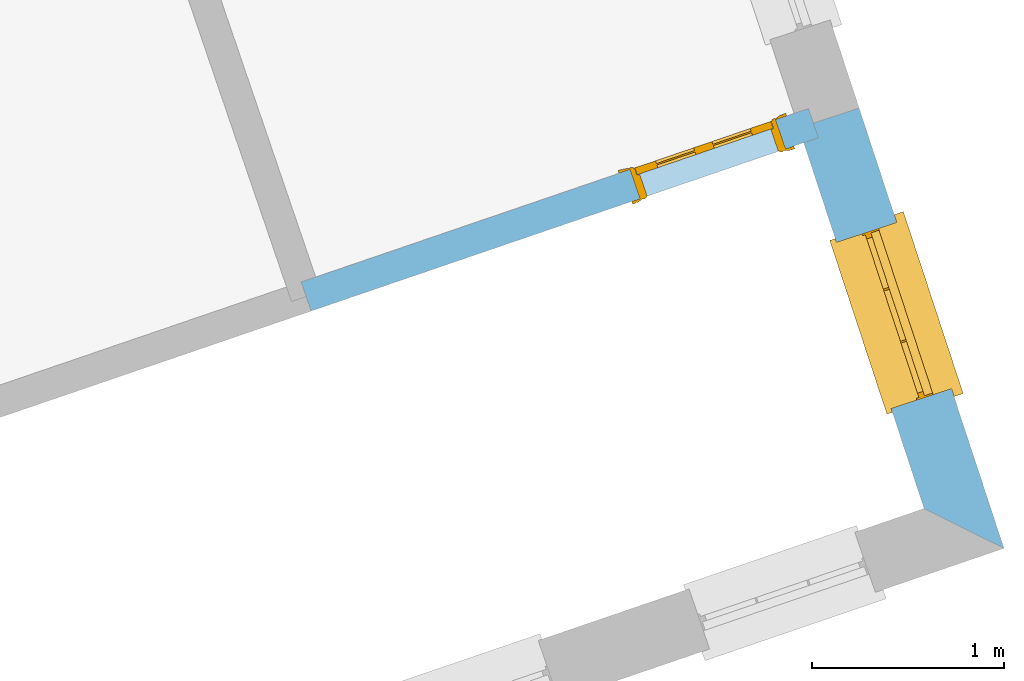
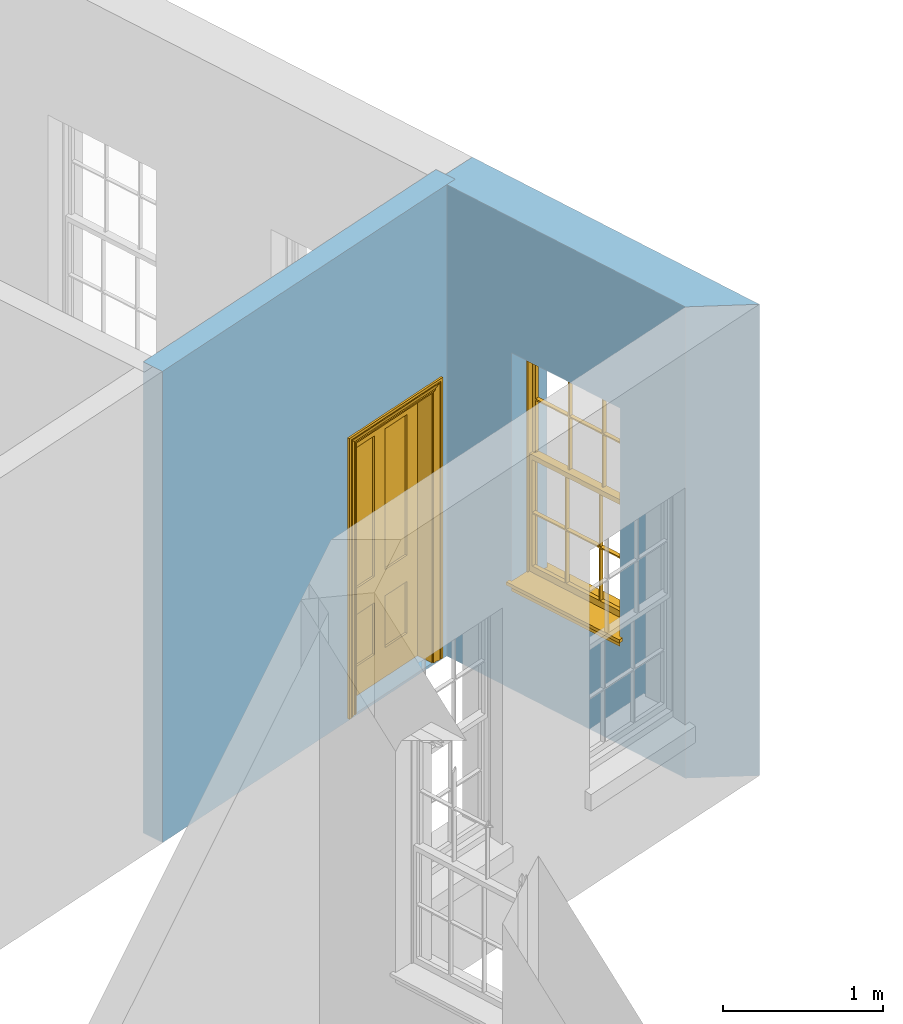
# One storey, part 7 of 10: 1 door, 1 window, 2 openings, plus 2 elements that do not belong to this part.
"""IFC2X3 building model written with IfcOpenShell, lengths in metres."""

import ifcopenshell
import ifcopenshell.guid

model = None  # the IFC model being written
_history = None  # IfcOwnerHistory: only IFC2X3 demands one
_inside = {}  # id of a spatial element -> (the spatial element, [elements in it])
_under = {}  # id of a project, library or spatial element -> (it, [spatial elements below it])
_declared = {}  # id of a project -> (the project, [libraries it declares])
_typed = {}  # id of a type object -> (the type object, [elements of that type])
_made_of = {}  # id of a material, layer set ... -> (it, [elements and type objects made of it])


def new_model(schema):
    """Start an empty IFC model of exactly this schema.

    Asked for "IFC4X3", IfcOpenShell would pick the latest addendum, in which some entities
    have other attributes; the version numbers below select the first issue.
    IFC2X3 requires an IfcOwnerHistory on every rooted entity: one is made here for all.
    """
    global model, _history
    if schema == "IFC4X3":
        model = ifcopenshell.file(schema_version=(4, 3, 0, 0))
    else:
        model = ifcopenshell.file(schema=schema)
    _inside.clear()
    _under.clear()
    _declared.clear()
    _typed.clear()
    _made_of.clear()
    _history = None
    if model.schema == "IFC2X3":
        org = make("IfcOrganization", Name="unknown")
        user = make(
            "IfcPersonAndOrganization",
            ThePerson=make("IfcPerson", FamilyName="unknown"),
            TheOrganization=org,
        )
        app = make(
            "IfcApplication",
            ApplicationDeveloper=org,
            Version="unknown",
            ApplicationFullName="unknown",
            ApplicationIdentifier="unknown",
        )
        _history = make(
            "IfcOwnerHistory",
            OwningUser=user,
            OwningApplication=app,
            ChangeAction="ADDED",
            CreationDate=0,
        )
    return model


def make(cls, **values):
    """One entity of the class cls with the attributes given. An attribute that is None is left unset."""
    return model.create_entity(
        cls, **{name: value for name, value in values.items() if value is not None}
    )


def rooted(cls, **values):
    """An entity with a GlobalId (a new one), such as an element, a storey or a relation."""
    return make(cls, GlobalId=ifcopenshell.guid.new(), OwnerHistory=_history, **values)


def si_unit(unit_type, name, prefix=None):
    """IfcSIUnit, for example si_unit("LENGTHUNIT", "METRE", prefix="MILLI")."""
    return make("IfcSIUnit", UnitType=unit_type, Prefix=prefix, Name=name)


def assignment(units):
    """IfcUnitAssignment: the units of a project."""
    return None if units is None else make("IfcUnitAssignment", Units=units)


def point(xyz):
    """IfcCartesianPoint."""
    return None if xyz is None else make("IfcCartesianPoint", Coordinates=xyz)


def direction(xyz):
    """IfcDirection."""
    return None if xyz is None else make("IfcDirection", DirectionRatios=xyz)


def frame(location, z_axis=None, x_axis=None):
    """IfcAxis2Placement3D, a coordinate frame: its origin and axes. An axis left out is left unset."""
    return make(
        "IfcAxis2Placement3D",
        Location=point(location),
        Axis=direction(z_axis),
        RefDirection=direction(x_axis),
    )


def origin():
    """The frame at (0, 0, 0) with its axes left unset."""
    return frame((0.0, 0.0, 0.0))


def place(relative_to, where):
    """IfcLocalPlacement: puts the frame where relative to a parent placement (None: the world)."""
    return make(
        "IfcLocalPlacement", PlacementRelTo=relative_to, RelativePlacement=where
    )


def context(
    kind, dimensions, precision=None, world=None, true_north=None, identifier=None
):
    """IfcGeometricRepresentationContext, for example the 3D "Model" context."""
    return make(
        "IfcGeometricRepresentationContext",
        ContextIdentifier=identifier,
        ContextType=kind,
        CoordinateSpaceDimension=dimensions,
        Precision=precision,
        WorldCoordinateSystem=world,
        TrueNorth=true_north,
    )


def subcontext(parent, identifier, kind, view, scale=None):
    """IfcGeometricRepresentationSubContext, for example "Body" below "Model"."""
    return make(
        "IfcGeometricRepresentationSubContext",
        ContextIdentifier=identifier,
        ContextType=kind,
        ParentContext=parent,
        TargetScale=scale,
        TargetView=view,
    )


def project(units=None, contexts=None):
    """IfcProject with its units and contexts."""
    return rooted(
        "IfcProject",
        Name="project",
        RepresentationContexts=contexts,
        UnitsInContext=assignment(units),
    )


def spatial(cls, under=None, at=None, **own):
    """A site, building, storey or space (cls), placed at a placement, below another one or the project."""
    s = rooted(cls, ObjectPlacement=at, **own)
    if under is not None:
        _under.setdefault(under.id(), (under, []))[1].append(s)
    return s


def polyline(points):
    """IfcPolyline through the points."""
    return make("IfcPolyline", Points=[point(p) for p in points])


def outline(outer, holes=None, kind="AREA"):
    """IfcArbitraryClosedProfileDef: a profile drawn as a closed curve; with holes, ...WithVoids."""
    if holes is None:
        return make("IfcArbitraryClosedProfileDef", ProfileType=kind, OuterCurve=outer)
    return make(
        "IfcArbitraryProfileDefWithVoids",
        ProfileType=kind,
        OuterCurve=outer,
        InnerCurves=holes,
    )


def extrude(swept, where, along, depth):
    """IfcExtrudedAreaSolid: the profile swept, set in the frame where, extruded along a direction by depth."""
    return make(
        "IfcExtrudedAreaSolid",
        SweptArea=swept,
        Position=where,
        ExtrudedDirection=direction(along),
        Depth=depth,
    )


def faces_of(points, faces, orient=None, outer=None):
    """IfcFace entities. A face is a list of loops; a loop is a list of indices into points, from 0.

    orient and outer hold one flag for each loop. By default every Orientation is true, the
    first loop of a face is its IfcFaceOuterBound and the others are IfcFaceBound.
    """
    made = []
    for i, loops in enumerate(faces):
        bounds = []
        for j, loop in enumerate(loops):
            is_outer = j == 0 if outer is None else outer[i][j]
            bounds.append(
                make(
                    "IfcFaceOuterBound" if is_outer else "IfcFaceBound",
                    Bound=make("IfcPolyLoop", Polygon=[points[k] for k in loop]),
                    Orientation=True if orient is None else orient[i][j],
                )
            )
        made.append(make("IfcFace", Bounds=bounds))
    return made


def faceted_brep(points, faces, orient=None, outer=None, voids=None):
    """IfcFacetedBrep: a solid bounded by flat faces; with voids (closed shells), ...WithVoids."""
    shared = [point(p) for p in points]
    hull = make("IfcClosedShell", CfsFaces=faces_of(shared, faces, orient, outer))
    if voids is None:
        return make("IfcFacetedBrep", Outer=hull)
    return make(
        "IfcFacetedBrepWithVoids",
        Outer=hull,
        Voids=[
            make(cls, CfsFaces=faces_of(shared, fs, o, b)) for cls, fs, o, b in voids
        ],
    )


def shape(context_of_items, identifier, shape_type, items):
    """IfcShapeRepresentation: the items that make up one representation, for example the "Body"."""
    return make(
        "IfcShapeRepresentation",
        ContextOfItems=context_of_items,
        RepresentationIdentifier=identifier,
        RepresentationType=shape_type,
        Items=items,
    )


def material(Name=None, Category=None):
    """IfcMaterial."""
    return make("IfcMaterial", Name=Name, Category=Category)


def layer(
    of_material, thickness, ventilated=None, Name=None, Category=None, Priority=None
):
    """IfcMaterialLayer: one layer of a wall or slab, of a material (None: an air gap)."""
    return make(
        "IfcMaterialLayer",
        Material=of_material,
        LayerThickness=thickness,
        IsVentilated=ventilated,
        Name=Name,
        Category=Category,
        Priority=Priority,
    )


def layer_set(layers, Name=None):
    """IfcMaterialLayerSet."""
    return make("IfcMaterialLayerSet", MaterialLayers=layers, LayerSetName=Name)


def layer_usage(for_layer_set, set_direction, sense, offset, extent=None):
    """IfcMaterialLayerSetUsage: how a layer set lies in its element."""
    return make(
        "IfcMaterialLayerSetUsage",
        ForLayerSet=for_layer_set,
        LayerSetDirection=set_direction,
        DirectionSense=sense,
        OffsetFromReferenceLine=offset,
        ReferenceExtent=extent,
    )


def made_of(thing, what):
    """Note that an element or type object is made of a material, layer set ...; save() writes the relation."""
    if what is not None:
        _made_of.setdefault(what.id(), (what, []))[1].append(thing)
    return thing


def element(
    cls,
    number,
    at=None,
    inside=None,
    cuts=None,
    type_object=None,
    material=None,
    context=None,
    identifier="Body",
    shape_type=None,
    held_by="IfcProductDefinitionShape",
    body=None,
    shapes=None,
    **own,
):
    """One element of the class cls, such as IfcWall. Its Tag is "e" and its number.

    at: its placement. inside: the storey or other place that contains it. cuts: it is an
    opening in that element (IfcRelVoidsElement). A single representation is given by context,
    identifier, shape_type and body (its items); several are given by shapes. held_by: the class
    of the entity that holds the representations. save() writes the other relations.
    """
    e = rooted(cls, Tag="e%d" % number, ObjectPlacement=at, **own)
    if body is not None:
        shapes = [shape(context, identifier, shape_type, body)]
    if shapes is not None:
        e.Representation = make(held_by, Representations=shapes)
    if inside is not None:
        _inside.setdefault(inside.id(), (inside, []))[1].append(e)
    if cuts is not None:
        rooted(
            "IfcRelVoidsElement", RelatingBuildingElement=cuts, RelatedOpeningElement=e
        )
    if type_object is not None:
        _typed.setdefault(type_object.id(), (type_object, []))[1].append(e)
    return made_of(e, material)


def fill(opening, filler):
    """IfcRelFillsElement: the door or window that sits in an opening."""
    return rooted(
        "IfcRelFillsElement",
        RelatingOpeningElement=opening,
        RelatedBuildingElement=filler,
    )


def aggregate(whole, parts):
    """IfcRelAggregates: a whole, such as a stair, and the parts it consists of."""
    return rooted("IfcRelAggregates", RelatingObject=whole, RelatedObjects=parts)


def save(model, path):
    """Write the relations noted so far, then the file.

    IfcRelAggregates (storeys below a building ...), IfcRelContainedInSpatialStructure (elements
    in a storey), IfcRelDefinesByType, IfcRelAssociatesMaterial and IfcRelDeclares: one each for
    every whole, place, type object, material and project.
    """
    for whole, parts in _under.values():
        aggregate(whole, parts)
    for where, things in _inside.values():
        rooted(
            "IfcRelContainedInSpatialStructure",
            RelatedElements=things,
            RelatingStructure=where,
        )
    for kind, things in _typed.values():
        rooted("IfcRelDefinesByType", RelatedObjects=things, RelatingType=kind)
    for what, things in _made_of.values():
        rooted("IfcRelAssociatesMaterial", RelatedObjects=things, RelatingMaterial=what)
    for by, libraries in _declared.values():
        rooted("IfcRelDeclares", RelatingContext=by, RelatedDefinitions=libraries)
    model.write(path)


model = new_model("IFC2X3")

# Units and contexts
model_context = context("Model", 3, world=origin())
body_context = subcontext(model_context, "Body", "Model", "MODEL_VIEW")
ifc_project = project(units=[si_unit("PLANEANGLEUNIT", "RADIAN"), si_unit("MASSUNIT", "GRAM", prefix="KILO"), si_unit("FORCEUNIT", "NEWTON", prefix="KILO"), si_unit("LENGTHUNIT", "METRE")], contexts=[model_context])

# Site, building, storey
site_placement = place(None, origin())
site = spatial("IfcSite", under=ifc_project, at=site_placement, CompositionType="ELEMENT")
building_placement = place(None, origin())
building = spatial("IfcBuilding", under=site, at=building_placement, Name="Building plot-2", CompositionType="ELEMENT")
storey_placement = place(None, frame((0.0, 0.0, 4.6)))
storey = spatial("IfcBuildingStorey", under=building, at=storey_placement, Name="Floor 1", CompositionType="ELEMENT", Elevation=4.6)

# Wall, opening, window
ifc_material_1 = material(Name="Masonry")
ifc_layer_1 = layer(ifc_material_1, 0.33, ventilated=False)
ifc_layer_set_1 = layer_set([ifc_layer_1], Name="My Wall")
ifc_layer_usage_1 = layer_usage(ifc_layer_set_1, "AXIS2", "NEGATIVE", 0.08)
wall_1_placement = place(storey_placement, origin())
wall_1 = element("IfcWallStandardCase", 1, at=wall_1_placement, inside=storey, material=ifc_layer_usage_1, Name="exterior", context=body_context, shape_type="SweptSolid", body=[
    extrude(outline(polyline([(36.6893138301649, 33.9125007833851), (37.1047195485034, 33.7057805140381), (36.3522408394225, 35.9930897647079), (36.0387683534412, 35.8899636257678), (36.6893138301649, 33.9125007833851)])), origin(), (0.0, 0.0, 1.0), 3.6),
])
opening_1_placement = place(storey_placement, frame((0.0, 0.0, 0.75)))
opening_1 = element("IfcOpeningElement", 2, at=opening_1_placement, cuts=wall_1, Name="Opening", ObjectType="Opening", context=body_context, shape_type="SweptSolid", body=[
    extrude(outline(polyline([(36.8320581914572, 34.5345891391136), (36.5476800507436, 35.3990132671227), (36.2342075647623, 35.2958871281825), (36.5185857054759, 34.4314630001735), (36.8320581914572, 34.5345891391136)])), origin(), (0.0, 0.0, 1.0), 1.82),
])
window_placement = place(storey_placement, frame((36.5945790354108, 34.4564632762802, 0.75), z_axis=(0.0, 0.0, 1.0), x_axis=(-0.284378140713635, 0.864424128009077, 0.0)))
window = element("IfcWindow", 3, at=window_placement, inside=storey, Name="circulation outside window", OverallHeight=1.82, OverallWidth=0.91, context=body_context, shape_type="Brep", held_by="IfcProductRepresentation", body=[
    faceted_brep([(0.033125, -0.105, 0.975209), (0.01, -0.105, 0.975209), (0.033125, -0.105, 1.376042), (0.876875, -0.105, 0.975209), (0.876875, -0.105, 1.376042), (0.9, -0.105, 0.975209), (0.876875, -0.105, 1.386042), (0.876875, -0.105, 1.786875), (0.9, -0.105, 1.81), (0.033125, -0.105, 1.786875), (0.033125, -0.105, 1.386042), (0.01, -0.105, 1.81), (0.876875, -0.135, 1.376042), (0.876875, -0.135, 0.975209), (0.9, -0.135, 0.937083), (0.033125, -0.135, 1.786875), (0.01, -0.135, 1.81), (0.033125, -0.135, 1.386042), (0.01, -0.135, 0.937083), (0.033125, -0.135, 0.975209), (0.033125, -0.135, 1.376042), (0.876875, -0.135, 1.786875), (0.876875, -0.135, 1.386042), (0.9, -0.135, 1.81), (0.033125, -0.105, 0.937083), (0.01, -0.105, 0.937083), (0.033125, -0.105, 0.53625), (0.876875, -0.105, 0.937083), (0.876875, -0.105, 0.53625), (0.9, -0.105, 0.937083), (0.876875, -0.105, 0.52625), (0.876875, -0.105, 0.125417), (0.9, -0.105, 0.077167), (0.033125, -0.105, 0.125417), (0.033125, -0.105, 0.52625), (0.01, -0.105, 0.077167), (-0.0425, -0.25, 0.01), (-0.0425, -0.3, 0.001667), (0.0, -0.25, 0.01), (0.9525, -0.25, 0.01), (0.91, -0.25, 0.01), (0.9525, -0.3, 0.001667), (-0.02, 0.08, 0.077167), (0.0, 0.08, 0.077167), (-0.02, 0.11, 0.077167), (0.0, -0.06, 0.077167), (0.01, -0.06, 0.077167), (0.91, -0.06, 0.077167), (0.91, 0.08, 0.077167), (0.9, -0.06, 0.077167), (0.93, 0.08, 0.077167), (0.93, 0.11, 0.077167), (0.01, -0.075, 0.975209), (0.9, -0.075, 0.975209), (0.876875, -0.075, 0.125417), (0.876875, -0.075, 0.52625), (0.9, -0.075, 0.077167), (0.876875, -0.075, 0.53625), (0.876875, -0.075, 0.937083), (0.033125, -0.075, 0.125417), (0.01, -0.075, 0.077167), (0.033125, -0.075, 0.52625), (0.033125, -0.075, 0.937083), (0.033125, -0.075, 0.53625), (-0.02, 0.08, 0.052167), (-0.02, 0.11, 0.052167), (0.93, 0.11, 0.052167), (0.93, 0.08, 0.052167), (0.91, 0.08, 0.052167), (0.0, 0.08, 0.052167), (0.91, -0.15, 0.026667), (0.0, -0.15, 0.026667), (-0.0425, -0.3, -0.123333), (0.9525, -0.3, -0.123333), (-0.0425, -0.25, -0.123333), (0.9525, -0.25, -0.123333), (0.01, -0.06, 1.81), (0.9, -0.06, 1.81), (0.0, -0.06, 1.82), (0.91, -0.06, 1.82), (0.01, -0.15, 0.077167), (0.9, -0.15, 0.077167), (0.592292, -0.105, 0.125417), (0.592292, -0.075, 0.125417), (0.317708, -0.075, 0.125417), (0.317708, -0.105, 0.125417), (0.592292, -0.105, 0.53625), (0.317708, -0.105, 0.53625), (0.317708, -0.105, 0.52625), (0.592292, -0.105, 0.52625), (0.592292, -0.075, 0.53625), (0.317708, -0.075, 0.53625), (0.592292, -0.135, 1.386042), (0.592292, -0.105, 1.386042), (0.317708, -0.105, 1.386042), (0.317708, -0.135, 1.386042), (0.317708, -0.135, 1.376042), (0.592292, -0.135, 1.376042), (0.317708, -0.105, 1.376042), (0.592292, -0.105, 1.376042), (0.602292, -0.135, 1.376042), (0.592292, -0.135, 0.975209), (0.602292, -0.135, 0.975209), (0.602292, -0.105, 0.975209), (0.592292, -0.105, 0.975209), (0.602292, -0.105, 1.376042), (0.602292, -0.075, 0.53625), (0.602292, -0.105, 0.53625), (0.317708, -0.075, 0.52625), (0.307708, -0.075, 0.125417), (0.307708, -0.075, 0.52625), (0.602292, -0.075, 0.52625), (0.602292, -0.075, 0.125417), (0.592292, -0.075, 0.52625), (0.307708, -0.075, 0.53625), (0.317708, -0.075, 0.937083), (0.307708, -0.075, 0.937083), (0.602292, -0.075, 0.937083), (0.592292, -0.075, 0.937083), (0.307708, -0.105, 0.52625), (0.307708, -0.105, 0.125417), (0.307708, -0.105, 0.53625), (0.307708, -0.105, 0.937083), (0.592292, -0.105, 0.937083), (0.317708, -0.105, 0.937083), (0.602292, -0.105, 0.937083), (0.602292, -0.105, 0.52625), (0.602292, -0.105, 0.125417), (0.307708, -0.135, 1.386042), (0.307708, -0.135, 1.376042), (0.307708, -0.135, 0.975209), (0.317708, -0.135, 0.975209), (0.317708, -0.135, 1.786875), (0.307708, -0.135, 1.786875), (0.602292, -0.135, 1.786875), (0.592292, -0.135, 1.786875), (0.602292, -0.135, 1.386042), (0.602292, -0.105, 1.386042), (0.307708, -0.105, 1.386042), (0.307708, -0.105, 1.786875), (0.317708, -0.105, 1.786875), (0.592292, -0.105, 1.786875), (0.602292, -0.105, 1.786875), (0.307708, -0.105, 1.376042), (0.317708, -0.105, 0.975209), (0.307708, -0.105, 0.975209), (0.91, -0.15, 1.82), (0.9, -0.15, 1.81), (0.01, -0.15, 1.81), (0.0, -0.15, 1.82), (0.91, -0.25, 0.0), (0.0, -0.25, 0.0), (0.91, 0.08, 0.0), (0.0, 0.08, 0.0)], [[[0, 1, 2]], [[3, 4, 5]], [[6, 7, 8]], [[9, 10, 11]], [[12, 13, 14]], [[15, 16, 17]], [[18, 19, 20]], [[21, 22, 23]], [[24, 25, 26]], [[27, 28, 29]], [[30, 31, 32]], [[33, 34, 35]], [[14, 27, 29]], [[25, 24, 18]], [[36, 37, 38]], [[39, 40, 41]], [[42, 43, 44]], [[45, 46, 43]], [[47, 48, 49]], [[50, 51, 48]], [[1, 0, 52]], [[5, 53, 3]], [[54, 55, 56]], [[57, 58, 53]], [[59, 60, 61]], [[62, 63, 52]], [[48, 43, 46, 49]], [[51, 44, 43, 48]], [[64, 42, 44, 65]], [[65, 44, 51, 66]], [[66, 51, 50, 67]], [[65, 66, 68, 69]], [[60, 56, 49, 46]], [[70, 71, 38, 40]], [[37, 41, 40, 38]], [[37, 72, 73, 41]], [[74, 75, 73, 72]], [[8, 11, 76, 77]], [[76, 78, 79, 77]], [[32, 35, 80, 81]], [[81, 80, 71, 70]], [[82, 83, 84, 85]], [[86, 87, 88, 89]], [[86, 90, 91, 87]], [[92, 93, 94, 95]], [[92, 95, 96, 97]], [[96, 98, 99, 97]], [[100, 97, 101, 102]], [[103, 104, 99, 105]], [[97, 99, 104, 101]], [[102, 103, 105, 100]], [[28, 57, 106, 107]], [[108, 84, 109, 110]], [[111, 112, 83, 113]], [[114, 110, 61, 63]], [[90, 113, 108, 91]], [[115, 91, 114, 116]], [[117, 106, 90, 118]], [[111, 106, 57, 55]], [[119, 110, 109, 120]], [[34, 61, 110, 119]], [[89, 113, 83, 82]], [[88, 108, 113, 89]], [[85, 84, 108, 88]], [[121, 114, 63, 26]], [[122, 116, 114, 121]], [[123, 118, 90, 86]], [[87, 91, 115, 124]], [[107, 106, 117, 125]], [[126, 111, 55, 30]], [[127, 112, 111, 126]], [[126, 30, 28, 107]], [[88, 119, 120, 85]], [[126, 89, 82, 127]], [[125, 123, 86, 107]], [[121, 26, 34, 119]], [[124, 122, 121, 87]], [[128, 17, 20, 129]], [[96, 129, 130, 131]], [[132, 133, 128, 95]], [[134, 135, 92, 136]], [[100, 12, 22, 136]], [[137, 6, 4, 105]], [[94, 138, 139, 140]], [[137, 93, 141, 142]], [[99, 98, 94, 93]], [[143, 2, 10, 138]], [[144, 145, 143, 98]], [[129, 143, 145, 130]], [[20, 2, 143, 129]], [[131, 144, 98, 96]], [[128, 138, 10, 17]], [[133, 139, 138, 128]], [[135, 141, 93, 92]], [[95, 94, 140, 132]], [[22, 6, 137, 136]], [[136, 137, 142, 134]], [[100, 105, 4, 12]], [[107, 86, 89, 126]], [[106, 111, 113, 90]], [[91, 108, 110, 114]], [[87, 121, 119, 88]], [[97, 100, 136, 92]], [[129, 96, 95, 128]], [[98, 143, 138, 94]], [[105, 99, 93, 137]], [[131, 101, 104, 144]], [[124, 115, 118, 123]], [[132, 140, 141, 135]], [[120, 109, 59, 33]], [[15, 9, 139, 133]], [[134, 142, 7, 21]], [[31, 54, 112, 127]], [[36, 74, 72, 37]], [[39, 41, 73, 75]], [[18, 14, 101, 131]], [[23, 16, 132, 135]], [[83, 56, 60, 84]], [[52, 53, 118, 115]], [[53, 52, 144, 104]], [[11, 8, 141, 140]], [[14, 18, 124, 123]], [[2, 1, 11, 10]], [[8, 5, 4, 6]], [[57, 53, 56, 55]], [[60, 52, 63, 61]], [[26, 25, 35, 34]], [[32, 29, 28, 30]], [[14, 23, 22, 12]], [[18, 20, 17, 16]], [[19, 0, 2, 20]], [[17, 10, 9, 15]], [[12, 4, 3, 13]], [[21, 7, 6, 22]], [[27, 58, 57, 28]], [[30, 55, 54, 31]], [[33, 59, 61, 34]], [[26, 63, 62, 24]], [[5, 8, 77, 53]], [[76, 11, 1, 52]], [[46, 45, 78, 76]], [[49, 77, 79, 47]], [[70, 146, 147, 81]], [[71, 80, 148, 149]], [[19, 130, 145, 0]], [[102, 13, 3, 103]], [[116, 122, 24, 62]], [[29, 32, 81, 14]], [[80, 35, 25, 18]], [[60, 46, 76, 52]], [[77, 49, 56, 53]], [[23, 14, 81, 147]], [[16, 148, 80, 18]], [[35, 85, 120]], [[120, 33, 35]], [[127, 82, 32]], [[32, 31, 127]], [[32, 82, 85, 35]], [[102, 101, 14]], [[14, 13, 102]], [[18, 131, 130]], [[130, 19, 18]], [[134, 21, 23]], [[23, 135, 134]], [[16, 15, 133]], [[133, 132, 16]], [[11, 140, 139]], [[139, 9, 11]], [[142, 141, 8]], [[8, 7, 142]], [[23, 147, 148, 16]], [[146, 149, 148, 147]], [[52, 115, 116]], [[116, 62, 52]], [[118, 53, 117]], [[58, 117, 53]], [[27, 125, 117, 58]], [[56, 83, 112]], [[112, 54, 56]], [[109, 84, 60]], [[60, 59, 109]], [[125, 27, 14]], [[14, 123, 125]], [[122, 124, 18]], [[18, 24, 122]], [[145, 144, 52]], [[52, 0, 145]], [[103, 3, 53]], [[53, 104, 103]], [[79, 78, 149, 146]], [[78, 45, 71, 149]], [[146, 70, 47, 79]], [[150, 75, 74, 151]], [[68, 66, 67]], [[48, 68, 67, 50]], [[69, 64, 65]], [[42, 64, 69, 43]], [[69, 68, 152, 153]], [[70, 68, 48, 47]], [[150, 152, 68, 70]], [[43, 69, 71, 45]], [[69, 153, 151, 71]], [[152, 150, 151, 153]], [[38, 151, 74, 36]], [[71, 151, 38]], [[39, 75, 150, 40]], [[40, 150, 70]]]),
])
fill(opening_1, window)

# Wall, opening, door
ifc_material_2 = material(Name="Masonry")
ifc_layer_2 = layer(ifc_material_2, 0.16, ventilated=False)
ifc_layer_set_2 = layer_set([ifc_layer_2], Name="My Wall")
ifc_layer_usage_2 = layer_usage(ifc_layer_set_2, "AXIS2", "NEGATIVE", 0.08)
wall_2_placement = place(storey_placement, origin())
wall_2 = element("IfcWallStandardCase", 4, at=wall_2_placement, inside=storey, material=ifc_layer_usage_2, Name="interior", context=body_context, shape_type="SweptSolid", body=[
    extrude(outline(polyline([(33.4533393772504, 35.0895075105363), (33.5051048113054, 34.9381128612349), (36.1406444004036, 35.8392665772238), (36.0888789663486, 35.9906612265252), (33.4533393772504, 35.0895075105363)])), origin(), (0.0, 0.0, 1.0), 3.6),
])
opening_2_placement = place(storey_placement, frame((0.0, 0.0, 0.0199999999999996)))
opening_2 = element("IfcOpeningElement", 5, at=opening_2_placement, cuts=wall_2, Name="Opening", ObjectType="Opening", context=body_context, shape_type="SweptSolid", body=[
    extrude(outline(polyline([(35.2133521734325, 35.5222032936369), (35.9703254199395, 35.7810304639119), (35.9185599858845, 35.9324251132133), (35.1615867393775, 35.6735979429383), (35.2133521734325, 35.5222032936369)])), origin(), (0.0, 0.0, 1.0), 2.1),
])
door_placement = place(storey_placement, frame((35.187469456405, 35.5979006182876, 0.0199999999999996), z_axis=(0.0, 0.0, 1.0), x_axis=(0.756973246507059, 0.258827170274991, 0.0)))
door = element("IfcDoor", 6, at=door_placement, inside=storey, Name="toilet inside door", OverallHeight=2.1, OverallWidth=0.8, context=body_context, shape_type="Brep", held_by="IfcProductRepresentation", body=[
    faceted_brep([(0.773, 0.08, 1.895), (0.66, 0.08, 1.895), (0.66, 0.08, 2.073), (0.773, 0.08, 2.073), (0.773, 0.08, 0.82), (0.66, 0.08, 0.82), (0.45, 0.08, 1.895), (0.45, 0.08, 2.073), (0.773, 0.08, 0.62), (0.66, 0.08, 0.62), (0.66, 0.065, 0.82), (0.66, 0.065, 1.895), (0.45, 0.065, 1.895), (0.35, 0.08, 1.895), (0.35, 0.08, 2.073), (0.773, 0.08, 0.225), (0.66, 0.08, 0.225), (0.45, 0.08, 0.62), (0.45, 0.08, 0.82), (0.45, 0.065, 0.82), (0.35, 0.08, 0.82), (0.14, 0.08, 2.073), (0.14, 0.08, 1.895), (0.773, 0.08, 0.0), (0.66, 0.08, 0.0), (0.66, 0.065, 0.225), (0.66, 0.065, 0.62), (0.45, 0.065, 0.62), (0.35, 0.08, 0.62), (0.35, 0.065, 0.82), (0.35, 0.065, 1.895), (0.14, 0.065, 1.895), (0.027, 0.08, 2.073), (0.027, 0.08, 1.895), (0.773, 0.042, 0.0), (0.66, 0.042, 0.0), (0.45, 0.08, 0.0), (0.45, 0.08, 0.225), (0.45, 0.065, 0.225), (0.35, 0.08, 0.225), (0.14, 0.08, 0.82), (0.14, 0.08, 0.62), (0.14, 0.065, 0.82), (0.027, 0.08, 0.82), (0.773, 0.042, 0.225), (0.66, 0.042, 0.225), (0.45, 0.042, 0.0), (0.35, 0.08, 0.0), (0.35, 0.065, 0.225), (0.35, 0.065, 0.62), (0.14, 0.065, 0.62), (0.027, 0.08, 0.62), (0.773, 0.042, 0.62), (0.66, 0.042, 0.62), (0.45, 0.042, 0.225), (0.35, 0.042, 0.0), (0.14, 0.08, 0.225), (0.14, 0.08, 0.0), (0.14, 0.065, 0.225), (0.027, 0.08, 0.225), (0.773, 0.042, 0.82), (0.66, 0.042, 0.82), (0.66, 0.057, 0.62), (0.66, 0.057, 0.225), (0.45, 0.057, 0.225), (0.35, 0.042, 0.225), (0.14, 0.042, 0.0), (0.027, 0.08, 0.0), (0.773, 0.042, 1.895), (0.66, 0.042, 1.895), (0.45, 0.042, 0.62), (0.45, 0.042, 0.82), (0.45, 0.057, 0.62), (0.35, 0.042, 0.62), (0.14, 0.042, 0.225), (0.027, 0.042, 0.0), (0.773, 0.042, 2.073), (0.66, 0.042, 2.073), (0.66, 0.057, 1.895), (0.66, 0.057, 0.82), (0.45, 0.057, 0.82), (0.35, 0.042, 0.82), (0.35, 0.057, 0.62), (0.35, 0.057, 0.225), (0.14, 0.057, 0.225), (0.027, 0.042, 0.225), (0.45, 0.042, 1.895), (0.45, 0.042, 2.073), (0.45, 0.057, 1.895), (0.35, 0.042, 1.895), (0.14, 0.042, 0.82), (0.14, 0.042, 0.62), (0.14, 0.057, 0.62), (0.027, 0.042, 0.62), (0.35, 0.042, 2.073), (0.35, 0.057, 1.895), (0.35, 0.057, 0.82), (0.14, 0.057, 0.82), (0.027, 0.042, 0.82), (0.14, 0.042, 2.073), (0.14, 0.042, 1.895), (0.14, 0.057, 1.895), (0.027, 0.042, 1.895), (0.027, 0.042, 2.073), (0.02, 0.085, 0.0), (0.005, 0.09, 0.0), (0.005, 0.09, 2.095), (0.02, 0.085, 2.08), (0.02, 0.08, 0.0), (0.0, 0.085, 0.0), (0.0, 0.085, 2.1), (0.795, 0.09, 2.095), (0.78, 0.085, 2.08), (0.02, 0.08, 2.08), (0.0, 0.08, 0.0), (-0.032, 0.095, 0.0), (-0.032, 0.095, 2.132), (0.8, 0.085, 2.1), (0.795, 0.09, 0.0), (0.78, 0.085, 0.0), (0.78, 0.08, 2.08), (0.04, 0.04, 0.0), (0.025, 0.04, 0.0), (0.025, 0.04, 2.075), (0.04, 0.04, 2.06), (-0.04, 0.09, 0.0), (-0.04, 0.09, 2.14), (0.832, 0.095, 2.132), (0.8, 0.085, 0.0), (0.78, 0.08, 0.0), (0.8, 0.08, 0.0), (0.86, 0.08, 0.0), (0.86, 0.08, 2.16), (0.8, 0.08, 2.1), (-0.06, 0.08, 2.16), (0.0, 0.08, 2.1), (-0.06, 0.08, 0.0), (-0.04, 0.095, 0.0), (-0.04, 0.095, 2.14), (0.84, 0.09, 2.14), (0.832, 0.095, 0.0), (0.84, 0.09, 0.0), (0.86, 0.095, 0.0), (0.86, 0.095, 2.16), (-0.06, 0.095, 2.16), (-0.06, 0.095, 0.0), (0.84, 0.095, 0.0), (0.84, 0.095, 2.14), (-0.025, -0.095, 0.0), (-0.025, -0.09, 0.0), (-0.025, -0.09, 2.125), (-0.025, -0.095, 2.125), (-0.017, -0.095, 0.0), (-0.017, -0.095, 2.117), (0.825, -0.09, 2.125), (0.825, -0.095, 2.125), (0.825, -0.095, 0.0), (0.845, -0.095, 0.0), (-0.045, -0.095, 2.145), (-0.045, -0.095, 0.0), (0.845, -0.095, 2.145), (0.015, -0.085, 0.0), (0.015, -0.085, 2.085), (0.817, -0.095, 2.117), (0.825, -0.09, 0.0), (0.845, -0.08, 0.0), (0.845, -0.08, 2.145), (-0.045, -0.08, 2.145), (-0.045, -0.08, 0.0), (0.02, -0.09, 0.0), (0.02, -0.09, 2.08), (0.785, -0.085, 2.085), (0.817, -0.095, 0.0), (0.8, -0.08, 0.0), (0.8, -0.08, 2.1), (0.0, -0.08, 2.1), (0.0, -0.08, 0.0), (0.035, -0.085, 0.0), (0.035, -0.085, 2.065), (0.78, -0.09, 2.08), (0.785, -0.085, 0.0), (0.775, 0.04, 2.075), (0.76, 0.04, 2.06), (0.035, -0.08, 2.065), (0.035, -0.08, 0.0), (0.765, -0.085, 2.065), (0.78, -0.09, 0.0), (0.765, -0.08, 0.0), (0.765, -0.08, 2.065), (0.765, -0.085, 0.0), (0.04, -0.08, 2.06), (0.04, -0.08, 0.0), (0.76, -0.08, 2.06), (0.76, -0.08, 0.0), (0.76, 0.04, 0.0), (0.775, 0.04, 0.0), (0.025, 0.08, 0.0), (0.025, 0.08, 2.075), (0.775, 0.08, 0.0), (0.775, 0.08, 2.075)], [[[0, 1, 2, 3]], [[1, 0, 4, 5]], [[1, 6, 7, 2]], [[8, 9, 5, 4]], [[1, 5, 10, 11]], [[6, 1, 11, 12]], [[6, 13, 14, 7]], [[15, 16, 9, 8]], [[9, 17, 18, 5]], [[5, 18, 19, 10]], [[10, 19, 12, 11]], [[18, 6, 12, 19]], [[18, 20, 13, 6]], [[21, 14, 13, 22]], [[23, 24, 16, 15]], [[9, 16, 25, 26]], [[17, 9, 26, 27]], [[17, 28, 20, 18]], [[13, 20, 29, 30]], [[22, 13, 30, 31]], [[32, 21, 22, 33]], [[34, 35, 24, 23]], [[24, 36, 37, 16]], [[16, 37, 38, 25]], [[25, 38, 27, 26]], [[37, 17, 27, 38]], [[37, 39, 28, 17]], [[40, 20, 28, 41]], [[20, 40, 42, 29]], [[31, 30, 29, 42]], [[40, 22, 31, 42]], [[33, 22, 40, 43]], [[35, 34, 44, 45]], [[35, 46, 36, 24]], [[36, 47, 39, 37]], [[28, 39, 48, 49]], [[41, 28, 49, 50]], [[43, 40, 41, 51]], [[45, 44, 52, 53]], [[46, 35, 45, 54]], [[46, 55, 47, 36]], [[56, 39, 47, 57]], [[39, 56, 58, 48]], [[50, 49, 48, 58]], [[56, 41, 50, 58]], [[51, 41, 56, 59]], [[53, 52, 60, 61]], [[45, 53, 62, 63]], [[54, 45, 63, 64]], [[55, 46, 54, 65]], [[55, 66, 57, 47]], [[59, 56, 57, 67]], [[61, 60, 68, 69]], [[70, 53, 61, 71]], [[53, 70, 72, 62]], [[72, 64, 63, 62]], [[70, 54, 64, 72]], [[65, 54, 70, 73]], [[65, 74, 66, 55]], [[67, 57, 66, 75]], [[69, 68, 76, 77]], [[61, 69, 78, 79]], [[71, 61, 79, 80]], [[73, 70, 71, 81]], [[65, 73, 82, 83]], [[74, 65, 83, 84]], [[74, 85, 75, 66]], [[86, 69, 77, 87]], [[69, 86, 88, 78]], [[88, 80, 79, 78]], [[86, 71, 80, 88]], [[81, 71, 86, 89]], [[73, 81, 90, 91]], [[73, 91, 92, 82]], [[83, 82, 92, 84]], [[91, 74, 84, 92]], [[91, 93, 85, 74]], [[89, 86, 87, 94]], [[81, 89, 95, 96]], [[90, 81, 96, 97]], [[90, 98, 93, 91]], [[94, 99, 100, 89]], [[89, 100, 101, 95]], [[101, 97, 96, 95]], [[100, 90, 97, 101]], [[100, 102, 98, 90]], [[99, 103, 102, 100]], [[32, 103, 99, 21]], [[102, 103, 32, 33]], [[98, 102, 33, 43]], [[21, 99, 94, 14]], [[94, 87, 7, 14]], [[7, 87, 77, 2]], [[76, 3, 2, 77]], [[43, 51, 93, 98]], [[51, 59, 85, 93]], [[67, 75, 85, 59]], [[34, 23, 15, 44]], [[44, 15, 8, 52]], [[52, 8, 4, 60]], [[0, 68, 60, 4]], [[0, 3, 76, 68]], [[104, 105, 106, 107]], [[104, 108, 109, 105]], [[105, 109, 110, 106]], [[107, 106, 111, 112]], [[107, 113, 108, 104]], [[114, 109, 108]], [[109, 115, 116, 110]], [[106, 110, 117, 111]], [[112, 111, 118, 119]], [[113, 107, 112, 120]], [[121, 122, 123, 124]], [[115, 109, 114, 125]], [[115, 125, 126, 116]], [[110, 116, 127, 117]], [[111, 117, 128, 118]], [[118, 128, 129, 119]], [[120, 112, 119, 129]], [[130, 129, 128]], [[130, 131, 132, 133]], [[133, 132, 134, 135]], [[135, 134, 136, 114]], [[136, 125, 114]], [[125, 137, 138, 126]], [[116, 126, 139, 127]], [[117, 127, 140, 128]], [[141, 130, 128, 140]], [[131, 130, 141]], [[131, 142, 143, 132]], [[132, 143, 144, 134]], [[134, 144, 145, 136]], [[137, 125, 136, 145]], [[143, 142, 146]], [[143, 146, 147]], [[137, 145, 144]], [[143, 147, 138]], [[138, 137, 144]], [[143, 138, 144]], [[126, 138, 147, 139]], [[127, 139, 141, 140]], [[142, 131, 141, 146]], [[139, 147, 146, 141]], [[148, 149, 150, 151]], [[149, 152, 153, 150]], [[151, 150, 154, 155]], [[155, 156, 157]], [[158, 159, 148]], [[158, 148, 151]], [[155, 157, 160]], [[158, 151, 155]], [[155, 160, 158]], [[152, 161, 162, 153]], [[150, 153, 163, 154]], [[155, 154, 164, 156]], [[156, 164, 165, 157]], [[157, 165, 166, 160]], [[160, 166, 167, 158]], [[158, 167, 168, 159]], [[161, 169, 170, 162]], [[153, 162, 171, 163]], [[154, 163, 172, 164]], [[165, 164, 173]], [[165, 173, 174, 166]], [[166, 174, 175, 167]], [[167, 175, 176, 168]], [[169, 177, 178, 170]], [[162, 170, 179, 171]], [[163, 171, 180, 172]], [[172, 180, 173, 164]], [[124, 123, 181, 182]], [[183, 178, 177, 184]], [[170, 178, 185, 179]], [[171, 179, 186, 180]], [[187, 173, 180]], [[185, 188, 187, 189]], [[188, 185, 178, 183]], [[179, 185, 189, 186]], [[189, 187, 180, 186]], [[190, 183, 184, 191]], [[192, 188, 183, 190]], [[191, 184, 122, 121]], [[124, 190, 191, 121]], [[193, 187, 188, 192]], [[182, 192, 190, 124]], [[184, 176, 122]], [[194, 195, 187, 193]], [[192, 182, 194, 193]], [[161, 176, 184]], [[114, 108, 122, 176]], [[173, 187, 195]], [[152, 149, 176, 161]], [[169, 161, 184, 177]], [[196, 122, 108]], [[176, 175, 135, 114]], [[173, 195, 129, 130]], [[176, 149, 168]], [[123, 122, 196, 197]], [[196, 108, 113, 197]], [[175, 174, 133, 135]], [[198, 129, 195]], [[133, 174, 173, 130]], [[159, 168, 149, 148]], [[181, 123, 197, 199]], [[197, 113, 120, 199]], [[199, 120, 129, 198]], [[195, 181, 199, 198]], [[195, 194, 182, 181]]]),
])
fill(opening_2, door)

save(model, "model.ifc")
